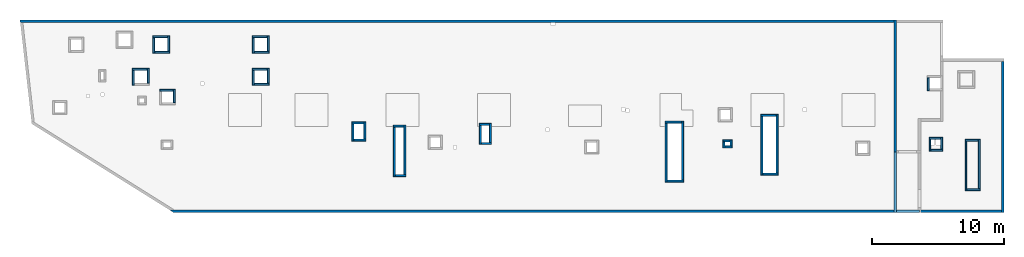
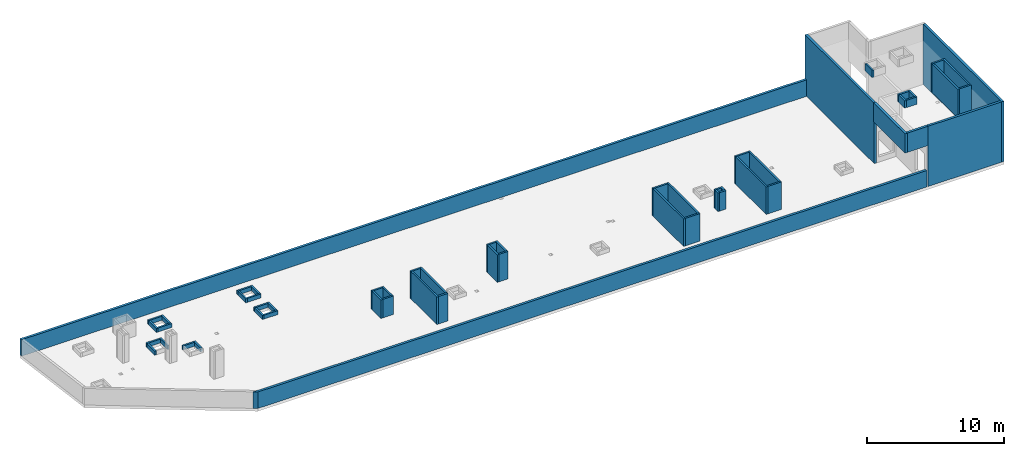
# One storey, part 2 of 3: 57 walls.
"""IFC4 building model written with IfcOpenShell, lengths in millimetres."""

import ifcopenshell
import ifcopenshell.guid

model = None  # the IFC model being written
_history = None  # IfcOwnerHistory: only IFC2X3 demands one
_inside = {}  # id of a spatial element -> (the spatial element, [elements in it])
_under = {}  # id of a project, library or spatial element -> (it, [spatial elements below it])
_declared = {}  # id of a project -> (the project, [libraries it declares])
_typed = {}  # id of a type object -> (the type object, [elements of that type])
_made_of = {}  # id of a material, layer set ... -> (it, [elements and type objects made of it])


def new_model(schema):
    """Start an empty IFC model of exactly this schema.

    Asked for "IFC4X3", IfcOpenShell would pick the latest addendum, in which some entities
    have other attributes; the version numbers below select the first issue.
    IFC2X3 requires an IfcOwnerHistory on every rooted entity: one is made here for all.
    """
    global model, _history
    if schema == "IFC4X3":
        model = ifcopenshell.file(schema_version=(4, 3, 0, 0))
    else:
        model = ifcopenshell.file(schema=schema)
    _inside.clear()
    _under.clear()
    _declared.clear()
    _typed.clear()
    _made_of.clear()
    _history = None
    if model.schema == "IFC2X3":
        org = make("IfcOrganization", Name="unknown")
        user = make(
            "IfcPersonAndOrganization",
            ThePerson=make("IfcPerson", FamilyName="unknown"),
            TheOrganization=org,
        )
        app = make(
            "IfcApplication",
            ApplicationDeveloper=org,
            Version="unknown",
            ApplicationFullName="unknown",
            ApplicationIdentifier="unknown",
        )
        _history = make(
            "IfcOwnerHistory",
            OwningUser=user,
            OwningApplication=app,
            ChangeAction="ADDED",
            CreationDate=0,
        )
    return model


def make(cls, **values):
    """One entity of the class cls with the attributes given. An attribute that is None is left unset."""
    return model.create_entity(
        cls, **{name: value for name, value in values.items() if value is not None}
    )


def entity(cls, *values):
    """Any entity or typed value of the class cls, its attributes in the order of the schema. None: left unset."""
    e = model.create_entity(cls)
    for i, value in enumerate(values):
        if value is not None:
            e[i] = value
    return e


def rooted(cls, **values):
    """An entity with a GlobalId (a new one), such as an element, a storey or a relation."""
    return make(cls, GlobalId=ifcopenshell.guid.new(), OwnerHistory=_history, **values)


def si_unit(unit_type, name, prefix=None):
    """IfcSIUnit, for example si_unit("LENGTHUNIT", "METRE", prefix="MILLI")."""
    return make("IfcSIUnit", UnitType=unit_type, Prefix=prefix, Name=name)


def converted_unit(unit_type, name, factor, base, dimensions=None, offset=None):
    """IfcConversionBasedUnit, such as the inch: factor (a typed value) times the base unit."""
    return make(
        "IfcConversionBasedUnit"
        if offset is None
        else "IfcConversionBasedUnitWithOffset",
        ConversionOffset=offset,
        Dimensions=None
        if dimensions is None
        else entity("IfcDimensionalExponents", *dimensions),
        UnitType=unit_type,
        Name=name,
        ConversionFactor=make(
            "IfcMeasureWithUnit", ValueComponent=factor, UnitComponent=base
        ),
    )


def derived_unit(unit_type, elements):
    """IfcDerivedUnit: a product of units, each with its exponent."""
    return make(
        "IfcDerivedUnit",
        Elements=[
            make("IfcDerivedUnitElement", Unit=unit, Exponent=power)
            for unit, power in elements
        ],
        UnitType=unit_type,
    )


def assignment(units):
    """IfcUnitAssignment: the units of a project."""
    return None if units is None else make("IfcUnitAssignment", Units=units)


def point(xyz):
    """IfcCartesianPoint."""
    return None if xyz is None else make("IfcCartesianPoint", Coordinates=xyz)


def direction(xyz):
    """IfcDirection."""
    return None if xyz is None else make("IfcDirection", DirectionRatios=xyz)


def frame(location, z_axis=None, x_axis=None):
    """IfcAxis2Placement3D, a coordinate frame: its origin and axes. An axis left out is left unset."""
    return make(
        "IfcAxis2Placement3D",
        Location=point(location),
        Axis=direction(z_axis),
        RefDirection=direction(x_axis),
    )


def origin():
    """The frame at (0, 0, 0) with its axes left unset."""
    return frame((0.0, 0.0, 0.0))


def place(relative_to, where):
    """IfcLocalPlacement: puts the frame where relative to a parent placement (None: the world)."""
    return make(
        "IfcLocalPlacement", PlacementRelTo=relative_to, RelativePlacement=where
    )


def context(
    kind, dimensions, precision=None, world=None, true_north=None, identifier=None
):
    """IfcGeometricRepresentationContext, for example the 3D "Model" context."""
    return make(
        "IfcGeometricRepresentationContext",
        ContextIdentifier=identifier,
        ContextType=kind,
        CoordinateSpaceDimension=dimensions,
        Precision=precision,
        WorldCoordinateSystem=world,
        TrueNorth=true_north,
    )


def subcontext(parent, identifier, kind, view, scale=None):
    """IfcGeometricRepresentationSubContext, for example "Body" below "Model"."""
    return make(
        "IfcGeometricRepresentationSubContext",
        ContextIdentifier=identifier,
        ContextType=kind,
        ParentContext=parent,
        TargetScale=scale,
        TargetView=view,
    )


def project(units=None, contexts=None):
    """IfcProject with its units and contexts."""
    return rooted(
        "IfcProject",
        Name="project",
        RepresentationContexts=contexts,
        UnitsInContext=assignment(units),
    )


def spatial(cls, under=None, at=None, **own):
    """A site, building, storey or space (cls), placed at a placement, below another one or the project."""
    s = rooted(cls, ObjectPlacement=at, **own)
    if under is not None:
        _under.setdefault(under.id(), (under, []))[1].append(s)
    return s


def point_list(points):
    """IfcCartesianPointList2D or 3D."""
    cls = (
        "IfcCartesianPointList2D" if len(points[0]) == 2 else "IfcCartesianPointList3D"
    )
    return make(cls, CoordList=points)


def indexed_curve(points, segments=None, self_intersect=None):
    """IfcIndexedPolyCurve: lines and arcs through numbered points (the first is 1)."""
    return make(
        "IfcIndexedPolyCurve",
        Points=point_list(points),
        Segments=segments,
        SelfIntersect=self_intersect,
    )


def outline(outer, holes=None, kind="AREA"):
    """IfcArbitraryClosedProfileDef: a profile drawn as a closed curve; with holes, ...WithVoids."""
    if holes is None:
        return make("IfcArbitraryClosedProfileDef", ProfileType=kind, OuterCurve=outer)
    return make(
        "IfcArbitraryProfileDefWithVoids",
        ProfileType=kind,
        OuterCurve=outer,
        InnerCurves=holes,
    )


def extrude(swept, where, along, depth):
    """IfcExtrudedAreaSolid: the profile swept, set in the frame where, extruded along a direction by depth."""
    return make(
        "IfcExtrudedAreaSolid",
        SweptArea=swept,
        Position=where,
        ExtrudedDirection=direction(along),
        Depth=depth,
    )


def shape(context_of_items, identifier, shape_type, items):
    """IfcShapeRepresentation: the items that make up one representation, for example the "Body"."""
    return make(
        "IfcShapeRepresentation",
        ContextOfItems=context_of_items,
        RepresentationIdentifier=identifier,
        RepresentationType=shape_type,
        Items=items,
    )


def material(Name=None, Category=None):
    """IfcMaterial."""
    return make("IfcMaterial", Name=Name, Category=Category)


def made_of(thing, what):
    """Note that an element or type object is made of a material, layer set ...; save() writes the relation."""
    if what is not None:
        _made_of.setdefault(what.id(), (what, []))[1].append(thing)
    return thing


def type_object(cls, material=None, **own):
    """A type object (cls), such as IfcWallType, which elements share."""
    return made_of(rooted(cls, **own), material)


def element(
    cls,
    number,
    at=None,
    inside=None,
    cuts=None,
    type_object=None,
    material=None,
    context=None,
    identifier="Body",
    shape_type=None,
    held_by="IfcProductDefinitionShape",
    body=None,
    shapes=None,
    **own,
):
    """One element of the class cls, such as IfcWall. Its Tag is "e" and its number.

    at: its placement. inside: the storey or other place that contains it. cuts: it is an
    opening in that element (IfcRelVoidsElement). A single representation is given by context,
    identifier, shape_type and body (its items); several are given by shapes. held_by: the class
    of the entity that holds the representations. save() writes the other relations.
    """
    e = rooted(cls, Tag="e%d" % number, ObjectPlacement=at, **own)
    if body is not None:
        shapes = [shape(context, identifier, shape_type, body)]
    if shapes is not None:
        e.Representation = make(held_by, Representations=shapes)
    if inside is not None:
        _inside.setdefault(inside.id(), (inside, []))[1].append(e)
    if cuts is not None:
        rooted(
            "IfcRelVoidsElement", RelatingBuildingElement=cuts, RelatedOpeningElement=e
        )
    if type_object is not None:
        _typed.setdefault(type_object.id(), (type_object, []))[1].append(e)
    return made_of(e, material)


def aggregate(whole, parts):
    """IfcRelAggregates: a whole, such as a stair, and the parts it consists of."""
    return rooted("IfcRelAggregates", RelatingObject=whole, RelatedObjects=parts)


def save(model, path):
    """Write the relations noted so far, then the file.

    IfcRelAggregates (storeys below a building ...), IfcRelContainedInSpatialStructure (elements
    in a storey), IfcRelDefinesByType, IfcRelAssociatesMaterial and IfcRelDeclares: one each for
    every whole, place, type object, material and project.
    """
    for whole, parts in _under.values():
        aggregate(whole, parts)
    for where, things in _inside.values():
        rooted(
            "IfcRelContainedInSpatialStructure",
            RelatedElements=things,
            RelatingStructure=where,
        )
    for kind, things in _typed.values():
        rooted("IfcRelDefinesByType", RelatedObjects=things, RelatingType=kind)
    for what, things in _made_of.values():
        rooted("IfcRelAssociatesMaterial", RelatedObjects=things, RelatingMaterial=what)
    for by, libraries in _declared.values():
        rooted("IfcRelDeclares", RelatingContext=by, RelatedDefinitions=libraries)
    model.write(path)


model = new_model("IFC4")

# Units and contexts
model_context = context("Model", 3, precision=0.01, world=origin(), true_north=direction((6.12303176911189e-17, 1.0)))
plan_context = context("Plan", 3, precision=0.01, world=origin(), true_north=direction((6.12303176911189e-17, 1.0)))
body_context = subcontext(model_context, "Body", "Model", "MODEL_VIEW")
ifc_project = project(units=[si_unit("LENGTHUNIT", "METRE", prefix="MILLI"), si_unit("AREAUNIT", "SQUARE_METRE"), si_unit("VOLUMEUNIT", "CUBIC_METRE"), converted_unit("PLANEANGLEUNIT", "DEGREE", entity("IfcRatioMeasure", 0.0174532925199433), si_unit("PLANEANGLEUNIT", "RADIAN"), dimensions=[0, 0, 0, 0, 0, 0, 0]), si_unit("MASSUNIT", "GRAM", prefix="KILO"), derived_unit("MASSDENSITYUNIT", [(si_unit("MASSUNIT", "GRAM", prefix="KILO"), 1), (si_unit("LENGTHUNIT", "METRE"), -3)]), derived_unit("MOMENTOFINERTIAUNIT", [(si_unit("LENGTHUNIT", "METRE"), 4)]), si_unit("TIMEUNIT", "SECOND"), si_unit("FREQUENCYUNIT", "HERTZ"), si_unit("THERMODYNAMICTEMPERATUREUNIT", "DEGREE_CELSIUS"), derived_unit("THERMALTRANSMITTANCEUNIT", [(si_unit("MASSUNIT", "GRAM", prefix="KILO"), 1), (si_unit("THERMODYNAMICTEMPERATUREUNIT", "KELVIN"), -1), (si_unit("TIMEUNIT", "SECOND"), -3)]), derived_unit("VOLUMETRICFLOWRATEUNIT", [(si_unit("LENGTHUNIT", "METRE"), 3), (si_unit("TIMEUNIT", "SECOND"), -1)]), derived_unit("MASSFLOWRATEUNIT", [(si_unit("MASSUNIT", "GRAM", prefix="KILO"), 1), (si_unit("TIMEUNIT", "SECOND"), -1)]), derived_unit("ROTATIONALFREQUENCYUNIT", [(si_unit("TIMEUNIT", "SECOND"), -1)]), si_unit("ELECTRICCURRENTUNIT", "AMPERE"), si_unit("ELECTRICVOLTAGEUNIT", "VOLT"), si_unit("POWERUNIT", "WATT"), si_unit("FORCEUNIT", "NEWTON", prefix="KILO"), si_unit("ILLUMINANCEUNIT", "LUX"), si_unit("LUMINOUSFLUXUNIT", "LUMEN"), si_unit("LUMINOUSINTENSITYUNIT", "CANDELA"), derived_unit("USERDEFINED", [(si_unit("MASSUNIT", "GRAM", prefix="KILO"), -1), (si_unit("LENGTHUNIT", "METRE"), -2), (si_unit("TIMEUNIT", "SECOND"), 3), (si_unit("LUMINOUSFLUXUNIT", "LUMEN"), 1)]), derived_unit("LINEARVELOCITYUNIT", [(si_unit("LENGTHUNIT", "METRE"), 1), (si_unit("TIMEUNIT", "SECOND"), -1)]), si_unit("PRESSUREUNIT", "PASCAL"), derived_unit("USERDEFINED", [(si_unit("LENGTHUNIT", "METRE"), -2), (si_unit("MASSUNIT", "GRAM", prefix="KILO"), 1), (si_unit("TIMEUNIT", "SECOND"), -2)]), derived_unit("LINEARFORCEUNIT", [(si_unit("MASSUNIT", "GRAM", prefix="KILO"), 1), (si_unit("LENGTHUNIT", "METRE"), 1), (si_unit("TIMEUNIT", "SECOND"), -2), (si_unit("LENGTHUNIT", "METRE"), -1)]), derived_unit("PLANARFORCEUNIT", [(si_unit("MASSUNIT", "GRAM", prefix="KILO"), 1), (si_unit("LENGTHUNIT", "METRE"), 1), (si_unit("TIMEUNIT", "SECOND"), -2), (si_unit("LENGTHUNIT", "METRE"), -2)])], contexts=[model_context, plan_context])

# Site, building, storey
site_placement = place(None, origin())
site = spatial("IfcSite", under=ifc_project, at=site_placement, CompositionType="ELEMENT")
building_placement = place(site_placement, origin())
building = spatial("IfcBuilding", under=site, at=building_placement, CompositionType="ELEMENT")
storey_placement = place(building_placement, frame((0.0, 0.0, 32250.0)))
storey = spatial("IfcBuildingStorey", under=building, at=storey_placement, CompositionType="ELEMENT", Elevation=32250.0)

# Walls
ifc_material = material()
wall_type_1 = type_object("IfcWallType", PredefinedType="STANDARD")
wall_1_placement = place(storey_placement, frame((-891.999731445319, 20399.9998657229, 0.0)))
element("IfcWall", 1, at=wall_1_placement, inside=storey, type_object=wall_type_1, material=ifc_material, PredefinedType="NOTDEFINED", context=body_context, shape_type="SweptSolid", body=[
    extrude(outline(indexed_curve([(66122.0, -99.999999999998), (66122.0, 99.9999999999999), (-5.16850425502453e-14, 99.9999999999989), (22.692092865985, -99.9999999999988), (223.975303985637, -99.9999999999982), (40192.0, -99.9999999999993), (40492.0, -99.9999999999983), (66122.0, -99.999999999998)], self_intersect=False)), origin(), (0.0, 0.0, 1.0), 1470.0),
])
wall_2_placement = place(storey_placement, frame((73469.9994506836, 17369.9992263555, 0.0), z_axis=(0.0, 0.0, 1.0), x_axis=(0.0, -1.0, 0.0)))
element("IfcWall", 2, at=wall_2_placement, inside=storey, type_object=wall_type_1, material=ifc_material, PredefinedType="NOTDEFINED", context=body_context, shape_type="SweptSolid", body=[
    extrude(outline(indexed_curve([(11440.0, 100.000000000003), (-1.48847715367481e-13, 100.000000000003), (1.48847715367481e-13, -100.000000000003), (11440.0, -100.000000000004), (11440.0, 100.000000000003)], self_intersect=False)), origin(), (0.0, 0.0, 1.0), 5370.0),
])
wall_3_placement = place(storey_placement, frame((73369.9994506836, 6029.99922635545, 0.0), z_axis=(0.0, 0.0, 1.0), x_axis=(-1.0, 0.0, 0.0)))
element("IfcWall", 3, at=wall_3_placement, inside=storey, type_object=wall_type_1, material=ifc_material, PredefinedType="NOTDEFINED", context=body_context, shape_type="SweptSolid", body=[
    extrude(outline(indexed_curve([(6189.99918212896, 100.0), (-3.22279133840974e-13, 100.0), (3.22279133840974e-13, -100.0), (6189.99918212896, -99.9999999999995), (6189.99918212896, 100.0)], self_intersect=False)), origin(), (0.0, 0.0, 1.0), 5370.0),
])
wall_4_placement = place(storey_placement, frame((65330.0002685547, 20499.9998657227, 0.0), z_axis=(0.0, 0.0, 1.0), x_axis=(0.0, -1.0, 0.0)))
element("IfcWall", 4, at=wall_4_placement, inside=storey, type_object=wall_type_1, material=ifc_material, PredefinedType="NOTDEFINED", context=body_context, shape_type="SweptSolid", body=[
    extrude(outline(indexed_curve([(10075.0006393667, 100.000000000004), (-2.66139747748769e-13, 100.000000000003), (2.66139747748769e-13, -100.000000000003), (10075.0006393667, -100.000000000002), (10075.0006393667, 100.000000000004)], self_intersect=False)), origin(), (0.0, 0.0, 1.0), 5370.0),
])
wall_5_placement = place(storey_placement, frame((67080.0002685546, 6029.99922635547, 0.0), z_axis=(0.0, 0.0, 1.0), x_axis=(-1.0, 0.0, 0.0)))
element("IfcWall", 5, at=wall_5_placement, inside=storey, type_object=wall_type_1, material=ifc_material, PredefinedType="NOTDEFINED", context=body_context, shape_type="SweptSolid", body=[
    extrude(outline(indexed_curve([(56662.6100905303, -100.0), (56342.5369381647, 99.9999999999997), (-3.22279133840974e-13, 100.0), (3.22279133840974e-13, -100.0), (56285.1888101747, -100.000000000001), (56662.6100905303, -100.0)], self_intersect=False)), origin(), (0.0, 0.0, 1.0), 1470.0),
])
wall_6_placement = place(storey_placement, frame((65330.0002685547, 10524.999226356, 3650.0), z_axis=(0.0, 0.0, 1.0), x_axis=(0.0, -1.0, 0.0)))
element("IfcWall", 6, at=wall_6_placement, inside=storey, type_object=wall_type_1, material=ifc_material, PredefinedType="NOTDEFINED", context=body_context, shape_type="SweptSolid", body=[
    extrude(outline(indexed_curve([(4595.00000000053, 100.000000000003), (0.0, 100.000000000003), (0.0, -100.000000000003), (4595.00000000053, -100.000000000003), (4595.00000000053, 100.000000000003)], self_intersect=False)), origin(), (0.0, 0.0, 1.0), 1720.0),
])
wall_7_placement = place(storey_placement, frame((65430.0002685547, 6029.99922635547, 3650.0)))
element("IfcWall", 7, at=wall_7_placement, inside=storey, type_object=wall_type_1, material=ifc_material, PredefinedType="NOTDEFINED", context=body_context, shape_type="SweptSolid", body=[
    extrude(outline(indexed_curve([(1749.99999999991, 100.0), (1.66594942968991e-13, 100.0), (-1.66594942968991e-13, -100.0), (1749.99999999991, -99.9999999999997), (1749.99999999991, 100.0)], self_intersect=False)), origin(), (0.0, 0.0, 1.0), 1720.0),
])
wall_type_2 = type_object("IfcWallType", PredefinedType="STANDARD")
wall_8_placement = place(storey_placement, frame((9150.00026855469, 19224.9998657229, 0.0)))
element("IfcWall", 8, at=wall_8_placement, inside=storey, type_object=wall_type_2, material=ifc_material, PredefinedType="NOTDEFINED", context=body_context, shape_type="SweptSolid", body=[
    extrude(outline(indexed_curve([(1150.0, 75.0000000000003), (0.0, 75.0000000000003), (0.0, -75.0000000000003), (1150.0, -75.0000000000003), (1150.0, 75.0000000000003)], self_intersect=False)), origin(), (0.0, 0.0, 1.0), 349.999999999998),
])
wall_9_placement = place(storey_placement, frame((9225.00026855469, 17999.9998657229, 0.0), z_axis=(0.0, 0.0, 1.0), x_axis=(0.0, 1.0, 0.0)))
element("IfcWall", 9, at=wall_9_placement, inside=storey, type_object=wall_type_2, material=ifc_material, PredefinedType="NOTDEFINED", context=body_context, shape_type="SweptSolid", body=[
    extrude(outline(indexed_curve([(1150.00000000001, 75.0000000000003), (0.0, 75.0000000000003), (0.0, -75.0000000000003), (1150.00000000001, -75.0000000000003), (1150.00000000001, 75.0000000000003)], self_intersect=False)), origin(), (0.0, 0.0, 1.0), 349.999999999998),
])
wall_10_placement = place(storey_placement, frame((10450.0002685547, 18074.9998657229, 0.0), z_axis=(0.0, 0.0, 1.0), x_axis=(-1.0, 0.0, 0.0)))
element("IfcWall", 10, at=wall_10_placement, inside=storey, type_object=wall_type_2, material=ifc_material, PredefinedType="NOTDEFINED", context=body_context, shape_type="SweptSolid", body=[
    extrude(outline(indexed_curve([(1150.0, 75.0000000000003), (0.0, 75.0000000000003), (0.0, -75.0000000000003), (1150.0, -75.0000000000003), (1150.0, 75.0000000000003)], self_intersect=False)), origin(), (0.0, 0.0, 1.0), 349.999999999998),
])
wall_11_placement = place(storey_placement, frame((10375.0002685547, 19299.9998657229, 0.0), z_axis=(0.0, 0.0, 1.0), x_axis=(0.0, -1.0, 0.0)))
element("IfcWall", 11, at=wall_11_placement, inside=storey, type_object=wall_type_2, material=ifc_material, PredefinedType="NOTDEFINED", context=body_context, shape_type="SweptSolid", body=[
    extrude(outline(indexed_curve([(1150.00000000001, 75.0000000000003), (0.0, 75.0000000000003), (0.0, -75.0000000000003), (1150.00000000001, -75.0000000000003), (1150.00000000001, 75.0000000000003)], self_intersect=False)), origin(), (0.0, 0.0, 1.0), 349.999999999998),
])
wall_12_placement = place(storey_placement, frame((7600.00026855468, 16774.9992263564, 0.0)))
element("IfcWall", 12, at=wall_12_placement, inside=storey, type_object=wall_type_2, material=ifc_material, PredefinedType="NOTDEFINED", context=body_context, shape_type="SweptSolid", body=[
    extrude(outline(indexed_curve([(1150.0, 75.0000000000003), (0.0, 75.0000000000003), (0.0, -75.0000000000003), (1150.0, -75.0000000000003), (1150.0, 75.0000000000003)], self_intersect=False)), origin(), (0.0, 0.0, 1.0), 349.999999999998),
])
for number, where, z_axis, x_axis in (
    (13, (7675.00026855468, 15549.9992263564, 0.0), (0.0, 0.0, 1.0), (0.0, 1.0, 0.0)),
    (14, (8825.00026855468, 16849.9992263564, 0.0), (0.0, 0.0, 1.0), (0.0, -1.0, 0.0)),
):
    element("IfcWall", number, at=place(storey_placement, frame(where, z_axis=z_axis, x_axis=x_axis)), inside=storey, type_object=wall_type_2, material=ifc_material, PredefinedType="NOTDEFINED", context=body_context, shape_type="SweptSolid", body=[
        extrude(outline(indexed_curve([(1150.0, 75.0000000000003), (0.0, 75.0000000000003), (0.0, -75.0000000000003), (1150.0, -75.0000000000003), (1150.0, 75.0000000000003)], self_intersect=False)), origin(), (0.0, 0.0, 1.0), 349.999999999998),
    ])
wall_13_placement = place(storey_placement, frame((9700.00026855468, 15174.9992263564, 0.0)))
element("IfcWall", 15, at=wall_13_placement, inside=storey, type_object=wall_type_2, material=ifc_material, PredefinedType="NOTDEFINED", context=body_context, shape_type="SweptSolid", body=[
    extrude(outline(indexed_curve([(1000.0, 75.0000000000003), (0.0, 75.0000000000003), (0.0, -75.0000000000003), (1000.0, -75.0000000000003), (1000.0, 75.0000000000003)], self_intersect=False)), origin(), (0.0, 0.0, 1.0), 349.999999999998),
])
wall_14_placement = place(storey_placement, frame((10775.0002685547, 15249.9992263564, 0.0), z_axis=(0.0, 0.0, 1.0), x_axis=(0.0, -1.0, 0.0)))
element("IfcWall", 16, at=wall_14_placement, inside=storey, type_object=wall_type_2, material=ifc_material, PredefinedType="NOTDEFINED", context=body_context, shape_type="SweptSolid", body=[
    extrude(outline(indexed_curve([(999.999999999998, 75.0000000000003), (0.0, 75.0000000000003), (0.0, -75.0000000000003), (999.999999999998, -75.0000000000003), (999.999999999998, 75.0000000000003)], self_intersect=False)), origin(), (0.0, 0.0, 1.0), 349.999999999998),
])
wall_15_placement = place(storey_placement, frame((16670.0002685547, 19224.9998657228, 0.0)))
element("IfcWall", 17, at=wall_15_placement, inside=storey, type_object=wall_type_2, material=ifc_material, PredefinedType="NOTDEFINED", context=body_context, shape_type="SweptSolid", body=[
    extrude(outline(indexed_curve([(1150.0, 75.0000000000003), (0.0, 75.0000000000003), (0.0, -75.0000000000003), (1150.0, -75.0000000000003), (1150.0, 75.0000000000003)], self_intersect=False)), origin(), (0.0, 0.0, 1.0), 349.999999999998),
])
for number, where, z_axis, x_axis in (
    (18, (16745.0002685547, 17999.9998657228, 0.0), (0.0, 0.0, 1.0), (0.0, 1.0, 0.0)),
    (19, (17970.0002685547, 18074.9998657228, 0.0), (0.0, 0.0, 1.0), (-1.0, 0.0, 0.0)),
    (20, (17895.0002685547, 19299.9998657228, 0.0), (0.0, 0.0, 1.0), (0.0, -1.0, 0.0)),
):
    element("IfcWall", number, at=place(storey_placement, frame(where, z_axis=z_axis, x_axis=x_axis)), inside=storey, type_object=wall_type_2, material=ifc_material, PredefinedType="NOTDEFINED", context=body_context, shape_type="SweptSolid", body=[
        extrude(outline(indexed_curve([(1150.0, 75.0000000000003), (0.0, 75.0000000000003), (0.0, -75.0000000000003), (1150.0, -75.0000000000003), (1150.0, 75.0000000000003)], self_intersect=False)), origin(), (0.0, 0.0, 1.0), 349.999999999998),
    ])
wall_16_placement = place(storey_placement, frame((16670.0002685547, 16774.9998657228, 0.0)))
element("IfcWall", 21, at=wall_16_placement, inside=storey, type_object=wall_type_2, material=ifc_material, PredefinedType="NOTDEFINED", context=body_context, shape_type="SweptSolid", body=[
    extrude(outline(indexed_curve([(1150.0, 75.0000000000003), (0.0, 75.0000000000003), (0.0, -75.0000000000003), (1150.0, -75.0000000000003), (1150.0, 75.0000000000003)], self_intersect=False)), origin(), (0.0, 0.0, 1.0), 349.999999999998),
])
for number, where, z_axis, x_axis in (
    (22, (16745.0002685547, 15549.9998657228, 0.0), (0.0, 0.0, 1.0), (0.0, 1.0, 0.0)),
    (23, (17970.0002685547, 15624.9998657228, 0.0), (0.0, 0.0, 1.0), (-1.0, 0.0, 0.0)),
    (24, (17895.0002685547, 16849.9998657228, 0.0), (0.0, 0.0, 1.0), (0.0, -1.0, 0.0)),
):
    element("IfcWall", number, at=place(storey_placement, frame(where, z_axis=z_axis, x_axis=x_axis)), inside=storey, type_object=wall_type_2, material=ifc_material, PredefinedType="NOTDEFINED", context=body_context, shape_type="SweptSolid", body=[
        extrude(outline(indexed_curve([(1150.0, 75.0000000000003), (0.0, 75.0000000000003), (0.0, -75.0000000000003), (1150.0, -75.0000000000003), (1150.0, 75.0000000000003)], self_intersect=False)), origin(), (0.0, 0.0, 1.0), 349.999999999998),
    ])
wall_17_placement = place(storey_placement, frame((24225.0002685547, 12714.9992263563, 0.0)))
element("IfcWall", 25, at=wall_17_placement, inside=storey, type_object=wall_type_2, material=ifc_material, PredefinedType="NOTDEFINED", context=body_context, shape_type="SweptSolid", body=[
    extrude(outline(indexed_curve([(899.999999999999, 75.0000000000003), (0.0, 75.0000000000003), (0.0, -75.0000000000003), (899.999999999999, -75.0000000000003), (899.999999999999, 75.0000000000003)], self_intersect=False)), origin(), (0.0, 0.0, 1.0), 1650.00000000001),
])
wall_18_placement = place(storey_placement, frame((24300.0002685547, 11339.9992263563, 0.0), z_axis=(0.0, 0.0, 1.0), x_axis=(0.0, 1.0, 0.0)))
element("IfcWall", 26, at=wall_18_placement, inside=storey, type_object=wall_type_2, material=ifc_material, PredefinedType="NOTDEFINED", context=body_context, shape_type="SweptSolid", body=[
    extrude(outline(indexed_curve([(1300.00000000001, 75.0000000000003), (0.0, 75.0000000000003), (0.0, -75.0000000000003), (1300.00000000001, -75.0000000000003), (1300.00000000001, 75.0000000000003)], self_intersect=False)), origin(), (0.0, 0.0, 1.0), 1650.00000000001),
])
wall_19_placement = place(storey_placement, frame((25275.0002685547, 11414.9992263563, 0.0), z_axis=(0.0, 0.0, 1.0), x_axis=(-1.0, 0.0, 0.0)))
element("IfcWall", 27, at=wall_19_placement, inside=storey, type_object=wall_type_2, material=ifc_material, PredefinedType="NOTDEFINED", context=body_context, shape_type="SweptSolid", body=[
    extrude(outline(indexed_curve([(899.999999999999, 75.0000000000003), (0.0, 75.0000000000003), (0.0, -75.0000000000003), (899.999999999999, -75.0000000000003), (899.999999999999, 75.0000000000003)], self_intersect=False)), origin(), (0.0, 0.0, 1.0), 1650.00000000001),
])
wall_20_placement = place(storey_placement, frame((25200.0002685547, 12789.9992263563, 0.0), z_axis=(0.0, 0.0, 1.0), x_axis=(0.0, -1.0, 0.0)))
element("IfcWall", 28, at=wall_20_placement, inside=storey, type_object=wall_type_2, material=ifc_material, PredefinedType="NOTDEFINED", context=body_context, shape_type="SweptSolid", body=[
    extrude(outline(indexed_curve([(1300.00000000001, 75.0000000000003), (0.0, 75.0000000000003), (0.0, -75.0000000000003), (1300.00000000001, -75.0000000000003), (1300.00000000001, 75.0000000000003)], self_intersect=False)), origin(), (0.0, 0.0, 1.0), 1650.00000000001),
])
wall_21_placement = place(storey_placement, frame((27365.0002685546, 12474.9992263558, 0.0)))
element("IfcWall", 29, at=wall_21_placement, inside=storey, type_object=wall_type_2, material=ifc_material, PredefinedType="NOTDEFINED", context=body_context, shape_type="SweptSolid", body=[
    extrude(outline(indexed_curve([(800.000000000004, 75.0000000000003), (0.0, 75.0000000000003), (0.0, -75.0000000000003), (800.000000000004, -75.0000000000003), (800.000000000004, 75.0000000000003)], self_intersect=False)), origin(), (0.0, 0.0, 1.0), 2450.0),
])
wall_22_placement = place(storey_placement, frame((27440.0002685546, 8649.99922635578, 0.0), z_axis=(0.0, 0.0, 1.0), x_axis=(0.0, 1.0, 0.0)))
element("IfcWall", 30, at=wall_22_placement, inside=storey, type_object=wall_type_2, material=ifc_material, PredefinedType="NOTDEFINED", context=body_context, shape_type="SweptSolid", body=[
    extrude(outline(indexed_curve([(3750.0, 75.0000000000003), (0.0, 75.0000000000003), (0.0, -75.0000000000003), (3750.0, -75.0000000000003), (3750.0, 75.0000000000003)], self_intersect=False)), origin(), (0.0, 0.0, 1.0), 2450.0),
])
wall_23_placement = place(storey_placement, frame((28315.0002685547, 8724.99922635578, 0.0), z_axis=(0.0, 0.0, 1.0), x_axis=(-1.0, 0.0, 0.0)))
element("IfcWall", 31, at=wall_23_placement, inside=storey, type_object=wall_type_2, material=ifc_material, PredefinedType="NOTDEFINED", context=body_context, shape_type="SweptSolid", body=[
    extrude(outline(indexed_curve([(800.000000000004, 75.0000000000003), (0.0, 75.0000000000003), (0.0, -75.0000000000003), (800.000000000004, -75.0000000000003), (800.000000000004, 75.0000000000003)], self_intersect=False)), origin(), (0.0, 0.0, 1.0), 2450.0),
])
wall_24_placement = place(storey_placement, frame((28240.0002685547, 12549.9992263558, 0.0), z_axis=(0.0, 0.0, 1.0), x_axis=(0.0, -1.0, 0.0)))
element("IfcWall", 32, at=wall_24_placement, inside=storey, type_object=wall_type_2, material=ifc_material, PredefinedType="NOTDEFINED", context=body_context, shape_type="SweptSolid", body=[
    extrude(outline(indexed_curve([(3750.0, 75.0000000000003), (0.0, 75.0000000000003), (0.0, -75.0000000000003), (3750.0, -75.0000000000003), (3750.0, 75.0000000000003)], self_intersect=False)), origin(), (0.0, 0.0, 1.0), 2450.0),
])
wall_25_placement = place(storey_placement, frame((33870.0002685547, 12604.9992263558, 0.0)))
element("IfcWall", 33, at=wall_25_placement, inside=storey, type_object=wall_type_2, material=ifc_material, PredefinedType="NOTDEFINED", context=body_context, shape_type="SweptSolid", body=[
    extrude(outline(indexed_curve([(749.999999999998, 75.0000000000003), (0.0, 75.0000000000003), (0.0, -75.0000000000003), (749.999999999998, -75.0000000000003), (749.999999999998, 75.0000000000003)], self_intersect=False)), origin(), (0.0, 0.0, 1.0), 2450.0),
])
wall_26_placement = place(storey_placement, frame((33945.0002685547, 11079.9992263558, 0.0), z_axis=(0.0, 0.0, 1.0), x_axis=(0.0, 1.0, 0.0)))
element("IfcWall", 34, at=wall_26_placement, inside=storey, type_object=wall_type_2, material=ifc_material, PredefinedType="NOTDEFINED", context=body_context, shape_type="SweptSolid", body=[
    extrude(outline(indexed_curve([(1450.0, 75.0000000000003), (0.0, 75.0000000000003), (0.0, -75.0000000000003), (1450.0, -75.0000000000003), (1450.0, 75.0000000000003)], self_intersect=False)), origin(), (0.0, 0.0, 1.0), 2450.0),
])
wall_27_placement = place(storey_placement, frame((34770.0002685547, 11154.9992263558, 0.0), z_axis=(0.0, 0.0, 1.0), x_axis=(-1.0, 0.0, 0.0)))
element("IfcWall", 35, at=wall_27_placement, inside=storey, type_object=wall_type_2, material=ifc_material, PredefinedType="NOTDEFINED", context=body_context, shape_type="SweptSolid", body=[
    extrude(outline(indexed_curve([(749.999999999998, 75.0000000000003), (0.0, 75.0000000000003), (0.0, -75.0000000000003), (749.999999999998, -75.0000000000003), (749.999999999998, 75.0000000000003)], self_intersect=False)), origin(), (0.0, 0.0, 1.0), 2450.0),
])
wall_28_placement = place(storey_placement, frame((34695.0002685547, 12679.9992263558, 0.0), z_axis=(0.0, 0.0, 1.0), x_axis=(0.0, -1.0, 0.0)))
element("IfcWall", 36, at=wall_28_placement, inside=storey, type_object=wall_type_2, material=ifc_material, PredefinedType="NOTDEFINED", context=body_context, shape_type="SweptSolid", body=[
    extrude(outline(indexed_curve([(1450.0, 75.0000000000003), (0.0, 75.0000000000003), (0.0, -75.0000000000003), (1450.0, -75.0000000000003), (1450.0, 75.0000000000003)], self_intersect=False)), origin(), (0.0, 0.0, 1.0), 2450.0),
])
wall_29_placement = place(storey_placement, frame((47920.0002685547, 12764.9992263556, 0.0)))
element("IfcWall", 37, at=wall_29_placement, inside=storey, type_object=wall_type_2, material=ifc_material, PredefinedType="NOTDEFINED", context=body_context, shape_type="SweptSolid", body=[
    extrude(outline(indexed_curve([(1249.99999999999, 75.0000000000003), (0.0, 75.0000000000003), (0.0, -75.0000000000003), (1249.99999999999, -75.0000000000003), (1249.99999999999, 75.0000000000003)], self_intersect=False)), origin(), (0.0, 0.0, 1.0), 2450.0),
])
wall_30_placement = place(storey_placement, frame((47995.0002685547, 8239.99922635562, 0.0), z_axis=(0.0, 0.0, 1.0), x_axis=(0.0, 1.0, 0.0)))
element("IfcWall", 38, at=wall_30_placement, inside=storey, type_object=wall_type_2, material=ifc_material, PredefinedType="NOTDEFINED", context=body_context, shape_type="SweptSolid", body=[
    extrude(outline(indexed_curve([(4450.0, 75.0000000000003), (0.0, 75.0000000000003), (0.0, -75.0000000000003), (4450.0, -75.0000000000003), (4450.0, 75.0000000000003)], self_intersect=False)), origin(), (0.0, 0.0, 1.0), 2450.0),
])
wall_31_placement = place(storey_placement, frame((49320.0002685547, 8314.99922635562, 0.0), z_axis=(0.0, 0.0, 1.0), x_axis=(-1.0, 0.0, 0.0)))
element("IfcWall", 39, at=wall_31_placement, inside=storey, type_object=wall_type_2, material=ifc_material, PredefinedType="NOTDEFINED", context=body_context, shape_type="SweptSolid", body=[
    extrude(outline(indexed_curve([(1249.99999999999, 75.0000000000003), (0.0, 75.0000000000003), (0.0, -75.0000000000003), (1249.99999999999, -75.0000000000003), (1249.99999999999, 75.0000000000003)], self_intersect=False)), origin(), (0.0, 0.0, 1.0), 2450.0),
])
wall_32_placement = place(storey_placement, frame((49245.0002685547, 12839.9992263556, 0.0), z_axis=(0.0, 0.0, 1.0), x_axis=(0.0, -1.0, 0.0)))
element("IfcWall", 40, at=wall_32_placement, inside=storey, type_object=wall_type_2, material=ifc_material, PredefinedType="NOTDEFINED", context=body_context, shape_type="SweptSolid", body=[
    extrude(outline(indexed_curve([(4450.0, 75.0000000000003), (0.0, 75.0000000000003), (0.0, -75.0000000000003), (4450.0, -75.0000000000003), (4450.0, 75.0000000000003)], self_intersect=False)), origin(), (0.0, 0.0, 1.0), 2450.0),
])
wall_33_placement = place(storey_placement, frame((52300.0002685547, 11349.9992263561, 0.0)))
element("IfcWall", 41, at=wall_33_placement, inside=storey, type_object=wall_type_2, material=ifc_material, PredefinedType="NOTDEFINED", context=body_context, shape_type="SweptSolid", body=[
    extrude(outline(indexed_curve([(550.000000000014, 75.0000000000003), (0.0, 75.0000000000003), (0.0, -75.0000000000003), (550.000000000014, -75.0000000000003), (550.000000000014, 75.0000000000003)], self_intersect=False)), origin(), (0.0, 0.0, 1.0), 1650.00000000001),
])
wall_34_placement = place(storey_placement, frame((52375.0002685547, 10824.9992263561, 0.0), z_axis=(0.0, 0.0, 1.0), x_axis=(0.0, 1.0, 0.0)))
element("IfcWall", 42, at=wall_34_placement, inside=storey, type_object=wall_type_2, material=ifc_material, PredefinedType="NOTDEFINED", context=body_context, shape_type="SweptSolid", body=[
    extrude(outline(indexed_curve([(450.000000000006, 75.0000000000003), (0.0, 75.0000000000003), (0.0, -75.0000000000003), (450.000000000006, -75.0000000000003), (450.000000000006, 75.0000000000003)], self_intersect=False)), origin(), (0.0, 0.0, 1.0), 1650.00000000001),
])
wall_35_placement = place(storey_placement, frame((53000.0002685547, 10899.9992263561, 0.0), z_axis=(0.0, 0.0, 1.0), x_axis=(-1.0, 0.0, 0.0)))
element("IfcWall", 43, at=wall_35_placement, inside=storey, type_object=wall_type_2, material=ifc_material, PredefinedType="NOTDEFINED", context=body_context, shape_type="SweptSolid", body=[
    extrude(outline(indexed_curve([(550.000000000014, 75.0000000000003), (0.0, 75.0000000000003), (0.0, -75.0000000000003), (550.000000000014, -75.0000000000003), (550.000000000014, 75.0000000000003)], self_intersect=False)), origin(), (0.0, 0.0, 1.0), 1650.00000000001),
])
wall_36_placement = place(storey_placement, frame((52925.0002685547, 11424.9992263561, 0.0), z_axis=(0.0, 0.0, 1.0), x_axis=(0.0, -1.0, 0.0)))
element("IfcWall", 44, at=wall_36_placement, inside=storey, type_object=wall_type_2, material=ifc_material, PredefinedType="NOTDEFINED", context=body_context, shape_type="SweptSolid", body=[
    extrude(outline(indexed_curve([(450.000000000006, 75.0000000000003), (0.0, 75.0000000000003), (0.0, -75.0000000000003), (450.000000000006, -75.0000000000003), (450.000000000006, 75.0000000000003)], self_intersect=False)), origin(), (0.0, 0.0, 1.0), 1650.00000000001),
])
wall_37_placement = place(storey_placement, frame((55170.0002685547, 13284.9992263556, 0.0)))
element("IfcWall", 45, at=wall_37_placement, inside=storey, type_object=wall_type_2, material=ifc_material, PredefinedType="NOTDEFINED", context=body_context, shape_type="SweptSolid", body=[
    extrude(outline(indexed_curve([(1150.0, 75.0000000000003), (0.0, 75.0000000000003), (0.0, -75.0000000000003), (1150.0, -75.0000000000003), (1150.0, 75.0000000000003)], self_intersect=False)), origin(), (0.0, 0.0, 1.0), 2450.0),
])
wall_38_placement = place(storey_placement, frame((55245.0002685547, 8759.99922635556, 0.0), z_axis=(0.0, 0.0, 1.0), x_axis=(0.0, 1.0, 0.0)))
element("IfcWall", 46, at=wall_38_placement, inside=storey, type_object=wall_type_2, material=ifc_material, PredefinedType="NOTDEFINED", context=body_context, shape_type="SweptSolid", body=[
    extrude(outline(indexed_curve([(4450.0, 75.0000000000003), (0.0, 75.0000000000003), (0.0, -75.0000000000003), (4450.0, -75.0000000000003), (4450.0, 75.0000000000003)], self_intersect=False)), origin(), (0.0, 0.0, 1.0), 2450.0),
])
wall_39_placement = place(storey_placement, frame((56470.0002685547, 8834.99922635556, 0.0), z_axis=(0.0, 0.0, 1.0), x_axis=(-1.0, 0.0, 0.0)))
element("IfcWall", 47, at=wall_39_placement, inside=storey, type_object=wall_type_2, material=ifc_material, PredefinedType="NOTDEFINED", context=body_context, shape_type="SweptSolid", body=[
    extrude(outline(indexed_curve([(1150.0, 75.0000000000003), (0.0, 75.0000000000003), (0.0, -75.0000000000003), (1150.0, -75.0000000000003), (1150.0, 75.0000000000003)], self_intersect=False)), origin(), (0.0, 0.0, 1.0), 2450.0),
])
wall_40_placement = place(storey_placement, frame((56395.0002685547, 13359.9992263556, 0.0), z_axis=(0.0, 0.0, 1.0), x_axis=(0.0, -1.0, 0.0)))
element("IfcWall", 48, at=wall_40_placement, inside=storey, type_object=wall_type_2, material=ifc_material, PredefinedType="NOTDEFINED", context=body_context, shape_type="SweptSolid", body=[
    extrude(outline(indexed_curve([(4450.0, 75.0000000000003), (0.0, 75.0000000000003), (0.0, -75.0000000000003), (4450.0, -75.0000000000003), (4450.0, 75.0000000000003)], self_intersect=False)), origin(), (0.0, 0.0, 1.0), 2450.0),
])
wall_41_placement = place(storey_placement, frame((70619.9994506836, 11389.999226356, 3900.0)))
element("IfcWall", 49, at=wall_41_placement, inside=storey, type_object=wall_type_2, material=ifc_material, PredefinedType="NOTDEFINED", context=body_context, shape_type="SweptSolid", body=[
    extrude(outline(indexed_curve([(999.999999999981, 75.0000000000003), (0.0, 75.0000000000003), (0.0, -75.0000000000003), (999.999999999981, -75.0000000000003), (999.999999999981, 75.0000000000003)], self_intersect=False)), origin(), (0.0, 0.0, 1.0), 2550.0),
])
wall_42_placement = place(storey_placement, frame((70694.9994506836, 7564.99922635597, 3900.0), z_axis=(0.0, 0.0, 1.0), x_axis=(0.0, 1.0, 0.0)))
element("IfcWall", 50, at=wall_42_placement, inside=storey, type_object=wall_type_2, material=ifc_material, PredefinedType="NOTDEFINED", context=body_context, shape_type="SweptSolid", body=[
    extrude(outline(indexed_curve([(3750.0, 75.0000000000003), (0.0, 75.0000000000003), (0.0, -75.0000000000003), (3750.0, -75.0000000000003), (3750.0, 75.0000000000003)], self_intersect=False)), origin(), (0.0, 0.0, 1.0), 2550.0),
])
wall_43_placement = place(storey_placement, frame((71769.9994506836, 7639.99922635596, 3900.0), z_axis=(0.0, 0.0, 1.0), x_axis=(-1.0, 0.0, 0.0)))
element("IfcWall", 51, at=wall_43_placement, inside=storey, type_object=wall_type_2, material=ifc_material, PredefinedType="NOTDEFINED", context=body_context, shape_type="SweptSolid", body=[
    extrude(outline(indexed_curve([(999.999999999998, 75.0000000000007), (-1.16021478139113e-13, 75.0000000000003), (1.16021478139113e-13, -75.0000000000003), (999.999999999998, -74.9999999999998), (999.999999999998, 75.0000000000007)], self_intersect=False)), origin(), (0.0, 0.0, 1.0), 2550.0),
])
wall_44_placement = place(storey_placement, frame((71694.9994506836, 11464.999226356, 3900.0), z_axis=(0.0, 0.0, 1.0), x_axis=(0.0, -1.0, 0.0)))
element("IfcWall", 52, at=wall_44_placement, inside=storey, type_object=wall_type_2, material=ifc_material, PredefinedType="NOTDEFINED", context=body_context, shape_type="SweptSolid", body=[
    extrude(outline(indexed_curve([(3750.00000000001, 74.9999999999918), (3.41958040831072e-13, 75.0000000000003), (-3.41958040831072e-13, -75.0000000000003), (3750.0, -75.0000000000087), (3750.00000000001, 74.9999999999918)], self_intersect=False)), origin(), (0.0, 0.0, 1.0), 2550.0),
])
wall_45_placement = place(storey_placement, frame((67895.0002685547, 11559.999226356, 3900.0)))
element("IfcWall", 53, at=wall_45_placement, inside=storey, type_object=wall_type_2, material=ifc_material, PredefinedType="NOTDEFINED", context=body_context, shape_type="SweptSolid", body=[
    extrude(outline(indexed_curve([(900.000000000003, 75.0000000000003), (0.0, 75.0000000000003), (0.0, -75.0000000000003), (900.000000000003, -75.0000000000003), (900.000000000003, 75.0000000000003)], self_intersect=False)), origin(), (0.0, 0.0, 1.0), 650.0),
])
wall_46_placement = place(storey_placement, frame((67970.0002685547, 10584.999226356, 3900.0), z_axis=(0.0, 0.0, 1.0), x_axis=(0.0, 1.0, 0.0)))
element("IfcWall", 54, at=wall_46_placement, inside=storey, type_object=wall_type_2, material=ifc_material, PredefinedType="NOTDEFINED", context=body_context, shape_type="SweptSolid", body=[
    extrude(outline(indexed_curve([(900.000000000001, 75.0000000000003), (0.0, 75.0000000000003), (0.0, -75.0000000000003), (900.000000000001, -75.0000000000003), (900.000000000001, 75.0000000000003)], self_intersect=False)), origin(), (0.0, 0.0, 1.0), 650.0),
])
wall_47_placement = place(storey_placement, frame((68945.0002685547, 10659.999226356, 3900.0), z_axis=(0.0, 0.0, 1.0), x_axis=(-1.0, 0.0, 0.0)))
element("IfcWall", 55, at=wall_47_placement, inside=storey, type_object=wall_type_2, material=ifc_material, PredefinedType="NOTDEFINED", context=body_context, shape_type="SweptSolid", body=[
    extrude(outline(indexed_curve([(900.000000000003, 75.0000000000003), (0.0, 75.0000000000003), (0.0, -75.0000000000003), (900.000000000003, -75.0000000000003), (900.000000000003, 75.0000000000003)], self_intersect=False)), origin(), (0.0, 0.0, 1.0), 650.0),
])
wall_48_placement = place(storey_placement, frame((68870.0002685547, 11634.999226356, 3900.0), z_axis=(0.0, 0.0, 1.0), x_axis=(0.0, -1.0, 0.0)))
element("IfcWall", 56, at=wall_48_placement, inside=storey, type_object=wall_type_2, material=ifc_material, PredefinedType="NOTDEFINED", context=body_context, shape_type="SweptSolid", body=[
    extrude(outline(indexed_curve([(900.000000000001, 75.0000000000003), (0.0, 75.0000000000003), (0.0, -75.0000000000003), (900.000000000001, -75.0000000000003), (900.000000000001, 75.0000000000003)], self_intersect=False)), origin(), (0.0, 0.0, 1.0), 650.0),
])
wall_49_placement = place(storey_placement, frame((67845.0002685547, 15139.999226356, 3900.0), z_axis=(0.0, 0.0, 1.0), x_axis=(0.0, 1.0, 0.0)))
element("IfcWall", 57, at=wall_49_placement, inside=storey, type_object=wall_type_2, material=ifc_material, PredefinedType="NOTDEFINED", context=body_context, shape_type="SweptSolid", body=[
    extrude(outline(indexed_curve([(1000.0, 75.0000000000003), (0.0, 75.0000000000003), (0.0, -75.0000000000003), (1000.0, -75.0000000000003), (1000.0, 75.0000000000003)], self_intersect=False)), origin(), (0.0, 0.0, 1.0), 650.0),
])

save(model, "model.ifc")
